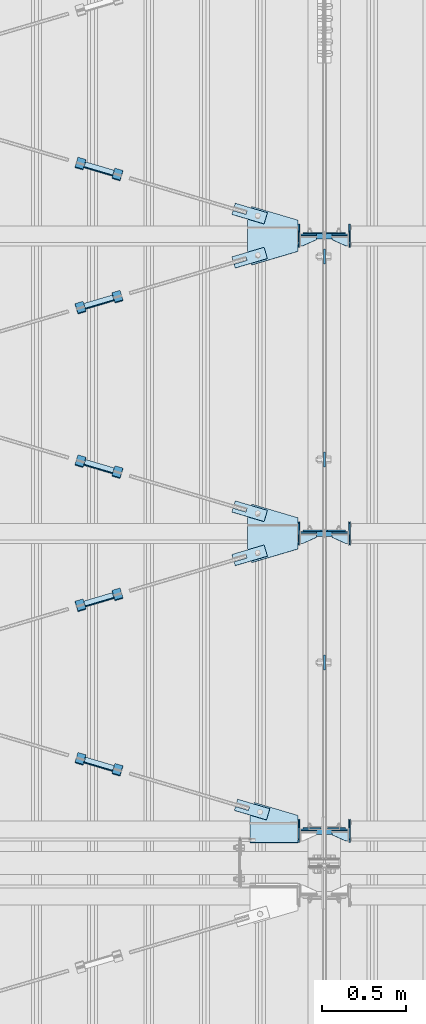
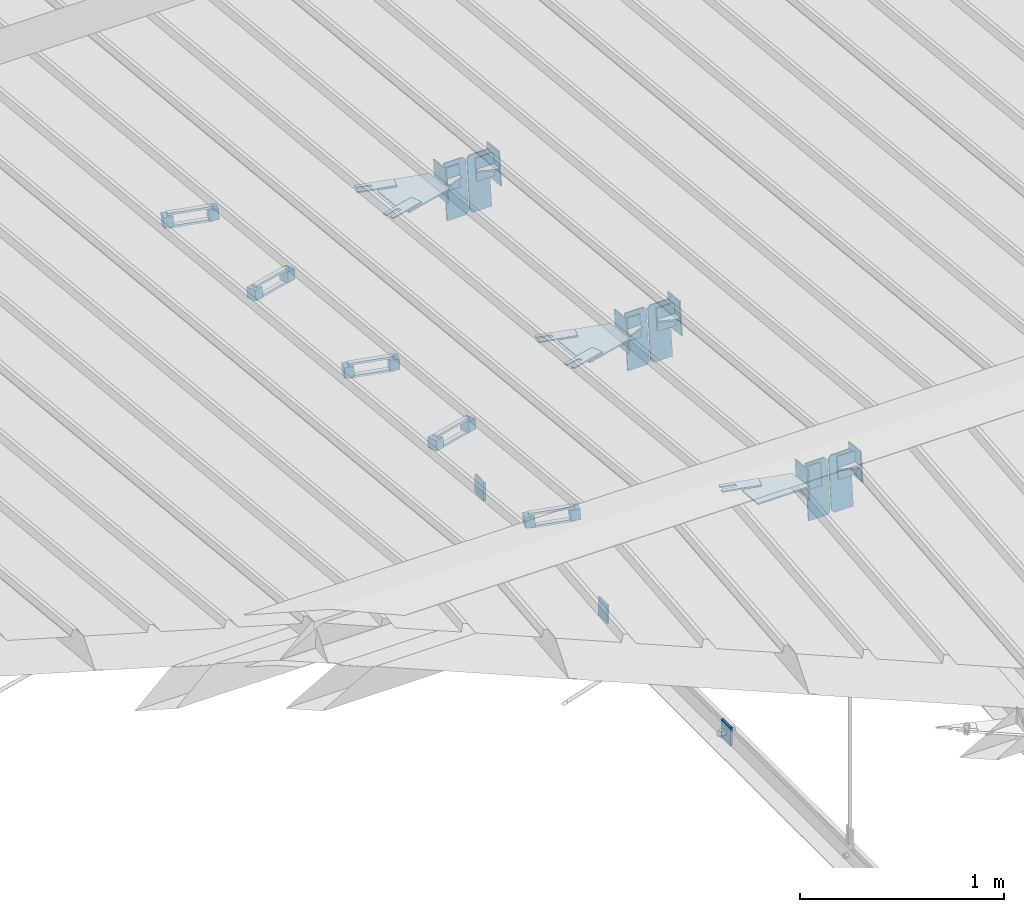
# One storey, part 120 of 709: 54 plates, 5 openings, 20 elements without a shape of their own.
"""IFC4 building model written with IfcOpenShell, lengths in millimetres."""

from ifc_helpers import new_model, si_unit, direction, frame, origin_with_axes, place, context, subcontext, project, spatial, line, indexed_curve, outline, extrude, material, element, aggregate, save


model = new_model("IFC4")

# Units and contexts
model_context = context("Model", 3, precision=0.2, world=origin_with_axes(), true_north=direction((0.0, 1.0)))
body_context = subcontext(model_context, "Body", "Model", "MODEL_VIEW")
ifc_project = project(units=[si_unit("LENGTHUNIT", "METRE", prefix="MILLI"), si_unit("AREAUNIT", "SQUARE_METRE"), si_unit("VOLUMEUNIT", "CUBIC_METRE"), si_unit("MASSUNIT", "GRAM", prefix="KILO"), si_unit("TIMEUNIT", "SECOND"), si_unit("PLANEANGLEUNIT", "RADIAN"), si_unit("SOLIDANGLEUNIT", "STERADIAN"), si_unit("THERMODYNAMICTEMPERATUREUNIT", "DEGREE_CELSIUS"), si_unit("LUMINOUSINTENSITYUNIT", "LUMEN")], contexts=[model_context])

# Site, building, storey
site_placement = place(None, origin_with_axes())
site = spatial("IfcSite", under=ifc_project, at=site_placement, CompositionType="ELEMENT")
building_placement = place(site_placement, origin_with_axes())
building = spatial("IfcBuilding", under=site, at=building_placement, Name="Undefined", CompositionType="ELEMENT")
storey_placement = place(building_placement, origin_with_axes())
storey = spatial("IfcBuildingStorey", under=building, at=storey_placement, Name="Undefined", CompositionType="ELEMENT", Elevation=0.0)

# Assembly, plates
assembly_1_placement = place(storey_placement, frame((10000.0, 21654.0, 7089.70002), z_axis=(-1.0, 0.0, 0.0), x_axis=(0.0, -0.9950371902, 0.099503719)))
assembly_1 = element("IfcElementAssembly", 1, at=assembly_1_placement, inside=storey)
ifc_material_1 = material(Name="C355-6", Category="STEEL")
plate_1_placement = place(assembly_1_placement, frame((10515.43997, 163.0, 127.0), z_axis=(-1.0, 0.0, 0.0), x_axis=(0.0, 0.0, -1.0)))
plate_1 = element("IfcPlate", 2, at=plate_1_placement, material=ifc_material_1, ObjectType="589", context=body_context, shape_type="SolidModel", body=[
    extrude(outline(indexed_curve([(0.0, 0.0), (108.0, 0.0), (123.0, 15.0), (123.0, 311.0), (108.0, 326.0), (0.0, 326.0)], segments=[line(1, 2, 3, 4, 5, 6, 1)])), frame((0.0, 0.0, 4.0), z_axis=(0.0, 0.0, 1.0), x_axis=(1.0, 0.0, 0.0)), (0.0, 0.0, -1.0), 8.0),
])
plate_2_placement = place(assembly_1_placement, frame((6951.15059, 163.0, 127.0), z_axis=(-1.0, 0.0, 0.0), x_axis=(0.0, 0.0, -1.0)))
plate_2 = element("IfcPlate", 3, at=plate_2_placement, material=ifc_material_1, ObjectType="585", context=body_context, shape_type="SolidModel", body=[
    extrude(outline(indexed_curve([(0.0, 0.0), (108.0, 0.0), (123.0, 15.0), (123.0, 311.0), (108.0, 326.0), (0.0, 326.0)], segments=[line(1, 2, 3, 4, 5, 6, 1)])), frame((0.0, 0.0, 4.0), z_axis=(0.0, 0.0, 1.0), x_axis=(1.0, 0.0, 0.0)), (0.0, 0.0, -1.0), 8.0),
])
plate_3_placement = place(assembly_1_placement, frame((8733.29528, 163.0, -127.0), z_axis=(1.0, 0.0, 0.0), x_axis=(0.0, 0.0, 1.0)))
plate_3 = element("IfcPlate", 4, at=plate_3_placement, material=ifc_material_1, ObjectType="585", context=body_context, shape_type="SolidModel", body=[
    extrude(outline(indexed_curve([(0.0, 0.0), (108.0, 0.0), (123.0, 15.0), (123.0, 311.0), (108.0, 326.0), (0.0, 326.0)], segments=[line(1, 2, 3, 4, 5, 6, 1)])), frame((0.0, 0.0, 4.0), z_axis=(0.0, 0.0, 1.0), x_axis=(1.0, 0.0, 0.0)), (0.0, 0.0, -1.0), 8.0),
])
plate_4_placement = place(assembly_1_placement, frame((8733.29528, 163.0, 127.0), z_axis=(-1.0, 0.0, 0.0), x_axis=(0.0, 0.0, -1.0)))
plate_4 = element("IfcPlate", 5, at=plate_4_placement, material=ifc_material_1, ObjectType="585", context=body_context, shape_type="SolidModel", body=[
    extrude(outline(indexed_curve([(0.0, 0.0), (108.0, 0.0), (123.0, 15.0), (123.0, 311.0), (108.0, 326.0), (0.0, 326.0)], segments=[line(1, 2, 3, 4, 5, 6, 1)])), frame((0.0, 0.0, 4.0), z_axis=(0.0, 0.0, 1.0), x_axis=(1.0, 0.0, 0.0)), (0.0, 0.0, -1.0), 8.0),
])
plate_5_placement = place(assembly_1_placement, frame((10515.43997, 163.0, -127.0), z_axis=(1.0, 0.0, 0.0), x_axis=(0.0, 0.0, 1.0)))
plate_5 = element("IfcPlate", 6, at=plate_5_placement, material=ifc_material_1, ObjectType="589", context=body_context, shape_type="SolidModel", body=[
    extrude(outline(indexed_curve([(0.0, 0.0), (108.0, 0.0), (123.0, 15.0), (123.0, 311.0), (108.0, 326.0), (0.0, 326.0)], segments=[line(1, 2, 3, 4, 5, 6, 1)])), frame((0.0, 0.0, 4.0), z_axis=(0.0, 0.0, 1.0), x_axis=(1.0, 0.0, 0.0)), (0.0, 0.0, -1.0), 8.0),
])
plate_6_placement = place(assembly_1_placement, frame((6951.15059, 163.0, -127.0), z_axis=(1.0, 0.0, 0.0), x_axis=(0.0, 0.0, 1.0)))
plate_6 = element("IfcPlate", 7, at=plate_6_placement, material=ifc_material_1, ObjectType="585", context=body_context, shape_type="SolidModel", body=[
    extrude(outline(indexed_curve([(0.0, 0.0), (108.0, 0.0), (123.0, 15.0), (123.0, 311.0), (108.0, 326.0), (0.0, 326.0)], segments=[line(1, 2, 3, 4, 5, 6, 1)])), frame((0.0, 0.0, 4.0), z_axis=(0.0, 0.0, 1.0), x_axis=(1.0, 0.0, 0.0)), (0.0, 0.0, -1.0), 8.0),
])
aggregate(assembly_1, [plate_1, plate_2, plate_3, plate_4, plate_5, plate_6])

# Assembly, plate
assembly_2_placement = place(storey_placement, frame((10000.0, 12149.25, 6100.00002), z_axis=(-1.0, 0.0, 0.0), x_axis=(0.0, 1.0, 0.0)))
assembly_2 = element("IfcElementAssembly", 8, at=assembly_2_placement, inside=storey)
plate_7_placement = place(assembly_2_placement, origin_with_axes())
plate_7 = element("IfcPlate", 9, at=plate_7_placement, material=ifc_material_1, ObjectType="491", context=body_context, shape_type="SolidModel", body=[
    extrude(outline(indexed_curve([(0.0, 0.0), (90.0, 0.0), (90.0, 110.0), (0.0, 110.0)], segments=[line(1, 2, 3, 4, 1)])), frame((0.0, 0.0, 6.0), z_axis=(0.0, 0.0, 1.0), x_axis=(1.0, 0.0, 0.0)), (0.0, 0.0, -1.0), 12.0),
])
aggregate(assembly_2, [plate_7])

assembly_3_placement = place(storey_placement, frame((10000.0, 13358.5, 6100.00002), z_axis=(-1.0, 0.0, 0.0), x_axis=(0.0, 1.0, 0.0)))
assembly_3 = element("IfcElementAssembly", 10, at=assembly_3_placement, inside=storey)
plate_8_placement = place(assembly_3_placement, origin_with_axes())
plate_8 = element("IfcPlate", 11, at=plate_8_placement, material=ifc_material_1, ObjectType="491", context=body_context, shape_type="SolidModel", body=[
    extrude(outline(indexed_curve([(0.0, 0.0), (90.0, 0.0), (90.0, 110.0), (0.0, 110.0)], segments=[line(1, 2, 3, 4, 1)])), frame((0.0, 0.0, 6.0), z_axis=(0.0, 0.0, 1.0), x_axis=(1.0, 0.0, 0.0)), (0.0, 0.0, -1.0), 12.0),
])
aggregate(assembly_3, [plate_8])

assembly_4_placement = place(storey_placement, frame((10000.0, 14567.75, 6100.00002), z_axis=(-1.0, 0.0, 0.0), x_axis=(0.0, 1.0, 0.0)))
assembly_4 = element("IfcElementAssembly", 12, at=assembly_4_placement, inside=storey)
plate_9_placement = place(assembly_4_placement, origin_with_axes())
plate_9 = element("IfcPlate", 13, at=plate_9_placement, material=ifc_material_1, ObjectType="491", context=body_context, shape_type="SolidModel", body=[
    extrude(outline(indexed_curve([(0.0, 0.0), (90.0, 0.0), (90.0, 110.0), (0.0, 110.0)], segments=[line(1, 2, 3, 4, 1)])), frame((0.0, 0.0, 6.0), z_axis=(0.0, 0.0, 1.0), x_axis=(1.0, 0.0, 0.0)), (0.0, 0.0, -1.0), 12.0),
])
aggregate(assembly_4, [plate_9])

# Assembly, plate, voiding feature
assembly_5_placement = place(storey_placement, frame((8657.949, 12567.50268, 8079.75375), z_axis=(0.2847296511, -0.9538504697, 0.095385047), x_axis=(0.9586078582, 0.2833165921, -0.028331659)))
assembly_5 = element("IfcElementAssembly", 14, at=assembly_5_placement, inside=storey)
plate_10_placement = place(assembly_5_placement, frame((1036.31721, 0.0, 35.0), z_axis=(0.0, 1.0, 0.0), x_axis=(0.0, 0.0, -1.0)))
plate_10 = element("IfcPlate", 15, at=plate_10_placement, material=ifc_material_1, ObjectType="574", context=body_context, shape_type="SolidModel", body=[
    extrude(outline(indexed_curve([(0.0, 0.0), (70.0, 0.0), (70.0, 200.0), (0.0, 200.0)], segments=[line(1, 2, 3, 4, 1)])), frame((0.0, 0.0, 4.0), z_axis=(0.0, 0.0, 1.0), x_axis=(1.0, 0.0, 0.0)), (0.0, 0.0, -1.0), 8.0),
])
voiding_feature_1_placement = place(plate_10_placement, frame((24.0, 120.0, 0.0), z_axis=(0.0, 0.0, 1.0), x_axis=(1.0, 0.0, 0.0)))
element("IfcVoidingFeature", 16, at=voiding_feature_1_placement, cuts=plate_10, Name="PLATE", PredefinedType="HOLE", context=body_context, shape_type="SolidModel", body=[
    extrude(outline(indexed_curve([(0.0, 0.0), (22.0, 0.0), (22.0, 85.0), (0.0, 85.0)], segments=[line(1, 2, 3, 4, 1)])), frame((0.0, 0.0, 6.5), z_axis=(0.0, 0.0, 1.0), x_axis=(1.0, 0.0, 0.0)), (0.0, 0.0, -1.0), 13.0),
])
aggregate(assembly_5, [plate_10])

# Assembly, plates
assembly_6_placement = place(storey_placement, frame((8776.73079, 12574.45368, 8109.20827), z_axis=(-0.9586078582, -0.2833165918, 0.0283316592), x_axis=(-0.2847296509, 0.9538504698, -0.095385047)))
assembly_6 = element("IfcElementAssembly", 17, at=assembly_6_placement, inside=storey)
ifc_material_2 = material(Name="Steel_Undefined", Category="STEEL")
plate_11_placement = place(assembly_6_placement, frame((15.0, -6.0, 230.0), z_axis=(0.0, 1.0, 0.0), x_axis=(1.0, 0.0, 0.0)))
plate_11 = element("IfcPlate", 18, at=plate_11_placement, material=ifc_material_2, ObjectType="484", context=body_context, shape_type="SolidModel", body=[
    extrude(outline(indexed_curve([(0.0, 0.0), (30.0, 0.0), (30.0, 230.0), (0.0, 230.0)], segments=[line(1, 2, 3, 4, 1)])), frame((0.0, 0.0, 6.0), z_axis=(0.0, 0.0, 1.0), x_axis=(1.0, 0.0, 0.0)), (0.0, 0.0, -1.0), 12.0),
])
plate_12_placement = place(assembly_6_placement, frame((15.0, 66.0, 230.0), z_axis=(0.0, 1.0, 0.0), x_axis=(1.0, 0.0, 0.0)))
plate_12 = element("IfcPlate", 19, at=plate_12_placement, material=ifc_material_2, ObjectType="484", context=body_context, shape_type="SolidModel", body=[
    extrude(outline(indexed_curve([(0.0, 0.0), (30.0, 0.0), (30.0, 230.0), (0.0, 230.0)], segments=[line(1, 2, 3, 4, 1)])), frame((0.0, 0.0, 6.0), z_axis=(0.0, 0.0, 1.0), x_axis=(1.0, 0.0, 0.0)), (0.0, 0.0, -1.0), 12.0),
])
plate_13_placement = place(assembly_6_placement, frame((0.0, 0.0, 230.0), z_axis=(0.0, 0.0, 1.0), x_axis=(1.0, 0.0, 0.0)))
plate_13 = element("IfcPlate", 20, at=plate_13_placement, material=ifc_material_2, ObjectType="483", context=body_context, shape_type="SolidModel", body=[
    extrude(outline(indexed_curve([(0.0, 0.0), (60.0, 0.0), (60.0, 60.0), (0.0, 60.0)], segments=[line(1, 2, 3, 4, 1)])), frame((0.0, 0.0, 25.0), z_axis=(0.0, 0.0, 1.0), x_axis=(1.0, 0.0, 0.0)), (0.0, 0.0, -1.0), 50.0),
])
plate_14_placement = place(assembly_6_placement, origin_with_axes())
plate_14 = element("IfcPlate", 21, at=plate_14_placement, material=ifc_material_2, ObjectType="482", context=body_context, shape_type="SolidModel", body=[
    extrude(outline(indexed_curve([(0.0, 0.0), (60.0, 0.0), (60.0, 60.0), (0.0, 60.0)], segments=[line(1, 2, 3, 4, 1)])), frame((0.0, 0.0, 25.0), z_axis=(0.0, 0.0, 1.0), x_axis=(1.0, 0.0, 0.0)), (0.0, 0.0, -1.0), 50.0),
])
aggregate(assembly_6, [plate_11, plate_12, plate_13, plate_14])

# Assembly, plate, voiding feature
assembly_7_placement = place(storey_placement, frame((8657.949, 11587.48889, 8177.75513), z_axis=(-0.2847296511, -0.9538504697, 0.095385047), x_axis=(0.9586078582, -0.2833165921, 0.028331659)))
assembly_7 = element("IfcElementAssembly", 22, at=assembly_7_placement, inside=storey)
plate_15_placement = place(assembly_7_placement, frame((1051.31721, 0.0, 35.0), z_axis=(0.0, 1.0, 0.0), x_axis=(0.0, 0.0, -1.0)))
plate_15 = element("IfcPlate", 23, at=plate_15_placement, material=ifc_material_1, ObjectType="574", context=body_context, shape_type="SolidModel", body=[
    extrude(outline(indexed_curve([(0.0, 0.0), (70.0, 0.0), (70.0, 200.0), (0.0, 200.0)], segments=[line(1, 2, 3, 4, 1)])), frame((0.0, 0.0, 4.0), z_axis=(0.0, 0.0, 1.0), x_axis=(1.0, 0.0, 0.0)), (0.0, 0.0, -1.0), 8.0),
])
voiding_feature_2_placement = place(plate_15_placement, frame((24.0, 120.0, 0.0), z_axis=(0.0, 0.0, 1.0), x_axis=(1.0, 0.0, 0.0)))
element("IfcVoidingFeature", 24, at=voiding_feature_2_placement, cuts=plate_15, Name="PLATE", PredefinedType="HOLE", context=body_context, shape_type="SolidModel", body=[
    extrude(outline(indexed_curve([(0.0, 0.0), (22.0, 0.0), (22.0, 85.0), (0.0, 85.0)], segments=[line(1, 2, 3, 4, 1)])), frame((0.0, 0.0, 6.5), z_axis=(0.0, 0.0, 1.0), x_axis=(1.0, 0.0, 0.0)), (0.0, 0.0, -1.0), 13.0),
])
aggregate(assembly_7, [plate_15])

# Assembly, plates
assembly_8_placement = place(storey_placement, frame((8759.64701, 11529.27708, 8213.72594), z_axis=(-0.9586078582, 0.2833165918, -0.0283316592), x_axis=(0.2847296509, 0.9538504698, -0.095385047)))
assembly_8 = element("IfcElementAssembly", 25, at=assembly_8_placement, inside=storey)
plate_16_placement = place(assembly_8_placement, frame((15.0, 66.0, 230.0), z_axis=(0.0, 1.0, 0.0), x_axis=(1.0, 0.0, 0.0)))
plate_16 = element("IfcPlate", 26, at=plate_16_placement, material=ifc_material_2, ObjectType="484", context=body_context, shape_type="SolidModel", body=[
    extrude(outline(indexed_curve([(0.0, 0.0), (30.0, 0.0), (30.0, 230.0), (0.0, 230.0)], segments=[line(1, 2, 3, 4, 1)])), frame((0.0, 0.0, 6.0), z_axis=(0.0, 0.0, 1.0), x_axis=(1.0, 0.0, 0.0)), (0.0, 0.0, -1.0), 12.0),
])
plate_17_placement = place(assembly_8_placement, frame((0.0, 0.0, 230.0), z_axis=(0.0, 0.0, 1.0), x_axis=(1.0, 0.0, 0.0)))
plate_17 = element("IfcPlate", 27, at=plate_17_placement, material=ifc_material_2, ObjectType="483", context=body_context, shape_type="SolidModel", body=[
    extrude(outline(indexed_curve([(0.0, 0.0), (60.0, 0.0), (60.0, 60.0), (0.0, 60.0)], segments=[line(1, 2, 3, 4, 1)])), frame((0.0, 0.0, 25.0), z_axis=(0.0, 0.0, 1.0), x_axis=(1.0, 0.0, 0.0)), (0.0, 0.0, -1.0), 50.0),
])
plate_18_placement = place(assembly_8_placement, frame((15.0, -6.0, 230.0), z_axis=(0.0, 1.0, 0.0), x_axis=(1.0, 0.0, 0.0)))
plate_18 = element("IfcPlate", 28, at=plate_18_placement, material=ifc_material_2, ObjectType="484", context=body_context, shape_type="SolidModel", body=[
    extrude(outline(indexed_curve([(0.0, 0.0), (30.0, 0.0), (30.0, 230.0), (0.0, 230.0)], segments=[line(1, 2, 3, 4, 1)])), frame((0.0, 0.0, 6.0), z_axis=(0.0, 0.0, 1.0), x_axis=(1.0, 0.0, 0.0)), (0.0, 0.0, -1.0), 12.0),
])
plate_19_placement = place(assembly_8_placement, origin_with_axes())
plate_19 = element("IfcPlate", 29, at=plate_19_placement, material=ifc_material_2, ObjectType="482", context=body_context, shape_type="SolidModel", body=[
    extrude(outline(indexed_curve([(0.0, 0.0), (60.0, 0.0), (60.0, 60.0), (0.0, 60.0)], segments=[line(1, 2, 3, 4, 1)])), frame((0.0, 0.0, 25.0), z_axis=(0.0, 0.0, 1.0), x_axis=(1.0, 0.0, 0.0)), (0.0, 0.0, -1.0), 50.0),
])
aggregate(assembly_8, [plate_16, plate_17, plate_18, plate_19])

# Assembly, plate, voiding feature
assembly_9_placement = place(storey_placement, frame((8657.949, 14340.80292, 7902.42372), z_axis=(0.2847296511, -0.9538504697, 0.095385047), x_axis=(0.9586078582, 0.2833165921, -0.028331659)))
assembly_9 = element("IfcElementAssembly", 30, at=assembly_9_placement, inside=storey)
plate_20_placement = place(assembly_9_placement, frame((1036.31721, 0.0, 35.0), z_axis=(0.0, 1.0, 0.0), x_axis=(0.0, 0.0, -1.0)))
plate_20 = element("IfcPlate", 31, at=plate_20_placement, material=ifc_material_1, ObjectType="574", context=body_context, shape_type="SolidModel", body=[
    extrude(outline(indexed_curve([(0.0, 0.0), (70.0, 0.0), (70.0, 200.0), (0.0, 200.0)], segments=[line(1, 2, 3, 4, 1)])), frame((0.0, 0.0, 4.0), z_axis=(0.0, 0.0, 1.0), x_axis=(1.0, 0.0, 0.0)), (0.0, 0.0, -1.0), 8.0),
])
voiding_feature_3_placement = place(plate_20_placement, frame((24.0, 120.0, 0.0), z_axis=(0.0, 0.0, 1.0), x_axis=(1.0, 0.0, 0.0)))
element("IfcVoidingFeature", 32, at=voiding_feature_3_placement, cuts=plate_20, Name="PLATE", PredefinedType="HOLE", context=body_context, shape_type="SolidModel", body=[
    extrude(outline(indexed_curve([(0.0, 0.0), (22.0, 0.0), (22.0, 85.0), (0.0, 85.0)], segments=[line(1, 2, 3, 4, 1)])), frame((0.0, 0.0, 6.5), z_axis=(0.0, 0.0, 1.0), x_axis=(1.0, 0.0, 0.0)), (0.0, 0.0, -1.0), 13.0),
])
aggregate(assembly_9, [plate_20])

# Assembly, plates
assembly_10_placement = place(storey_placement, frame((8776.73079, 14347.75393, 7931.87825), z_axis=(-0.9586078582, -0.2833165918, 0.0283316592), x_axis=(-0.2847296509, 0.9538504698, -0.095385047)))
assembly_10 = element("IfcElementAssembly", 33, at=assembly_10_placement, inside=storey)
plate_21_placement = place(assembly_10_placement, frame((15.0, 66.0, 230.0), z_axis=(0.0, 1.0, 0.0), x_axis=(1.0, 0.0, 0.0)))
plate_21 = element("IfcPlate", 34, at=plate_21_placement, material=ifc_material_2, ObjectType="484", context=body_context, shape_type="SolidModel", body=[
    extrude(outline(indexed_curve([(0.0, 0.0), (30.0, 0.0), (30.0, 230.0), (0.0, 230.0)], segments=[line(1, 2, 3, 4, 1)])), frame((0.0, 0.0, 6.0), z_axis=(0.0, 0.0, 1.0), x_axis=(1.0, 0.0, 0.0)), (0.0, 0.0, -1.0), 12.0),
])
plate_22_placement = place(assembly_10_placement, frame((15.0, -6.0, 230.0), z_axis=(0.0, 1.0, 0.0), x_axis=(1.0, 0.0, 0.0)))
plate_22 = element("IfcPlate", 35, at=plate_22_placement, material=ifc_material_2, ObjectType="484", context=body_context, shape_type="SolidModel", body=[
    extrude(outline(indexed_curve([(0.0, 0.0), (30.0, 0.0), (30.0, 230.0), (0.0, 230.0)], segments=[line(1, 2, 3, 4, 1)])), frame((0.0, 0.0, 6.0), z_axis=(0.0, 0.0, 1.0), x_axis=(1.0, 0.0, 0.0)), (0.0, 0.0, -1.0), 12.0),
])
plate_23_placement = place(assembly_10_placement, origin_with_axes())
plate_23 = element("IfcPlate", 36, at=plate_23_placement, material=ifc_material_2, ObjectType="482", context=body_context, shape_type="SolidModel", body=[
    extrude(outline(indexed_curve([(0.0, 0.0), (60.0, 0.0), (60.0, 60.0), (0.0, 60.0)], segments=[line(1, 2, 3, 4, 1)])), frame((0.0, 0.0, 25.0), z_axis=(0.0, 0.0, 1.0), x_axis=(1.0, 0.0, 0.0)), (0.0, 0.0, -1.0), 50.0),
])
plate_24_placement = place(assembly_10_placement, frame((0.0, 0.0, 230.0), z_axis=(0.0, 0.0, 1.0), x_axis=(1.0, 0.0, 0.0)))
plate_24 = element("IfcPlate", 37, at=plate_24_placement, material=ifc_material_2, ObjectType="483", context=body_context, shape_type="SolidModel", body=[
    extrude(outline(indexed_curve([(0.0, 0.0), (60.0, 0.0), (60.0, 60.0), (0.0, 60.0)], segments=[line(1, 2, 3, 4, 1)])), frame((0.0, 0.0, 25.0), z_axis=(0.0, 0.0, 1.0), x_axis=(1.0, 0.0, 0.0)), (0.0, 0.0, -1.0), 50.0),
])
aggregate(assembly_10, [plate_21, plate_22, plate_23, plate_24])

# Assembly, plate, voiding feature
assembly_11_placement = place(storey_placement, frame((8657.949, 13360.78913, 8000.4251), z_axis=(-0.2847296511, -0.9538504697, 0.095385047), x_axis=(0.9586078582, -0.2833165921, 0.028331659)))
assembly_11 = element("IfcElementAssembly", 38, at=assembly_11_placement, inside=storey)
plate_25_placement = place(assembly_11_placement, frame((1036.31721, 0.0, 35.0), z_axis=(0.0, 1.0, 0.0), x_axis=(0.0, 0.0, -1.0)))
plate_25 = element("IfcPlate", 39, at=plate_25_placement, material=ifc_material_1, ObjectType="574", context=body_context, shape_type="SolidModel", body=[
    extrude(outline(indexed_curve([(0.0, 0.0), (70.0, 0.0), (70.0, 200.0), (0.0, 200.0)], segments=[line(1, 2, 3, 4, 1)])), frame((0.0, 0.0, 4.0), z_axis=(0.0, 0.0, 1.0), x_axis=(1.0, 0.0, 0.0)), (0.0, 0.0, -1.0), 8.0),
])
voiding_feature_4_placement = place(plate_25_placement, frame((24.0, 120.0, 0.0), z_axis=(0.0, 0.0, 1.0), x_axis=(1.0, 0.0, 0.0)))
element("IfcVoidingFeature", 40, at=voiding_feature_4_placement, cuts=plate_25, Name="PLATE", PredefinedType="HOLE", context=body_context, shape_type="SolidModel", body=[
    extrude(outline(indexed_curve([(0.0, 0.0), (22.0, 0.0), (22.0, 85.0), (0.0, 85.0)], segments=[line(1, 2, 3, 4, 1)])), frame((0.0, 0.0, 6.5), z_axis=(0.0, 0.0, 1.0), x_axis=(1.0, 0.0, 0.0)), (0.0, 0.0, -1.0), 13.0),
])
aggregate(assembly_11, [plate_25])

# Assembly, plates
assembly_12_placement = place(storey_placement, frame((8759.64701, 13302.57732, 8036.39591), z_axis=(-0.9586078582, 0.2833165918, -0.0283316592), x_axis=(0.2847296509, 0.9538504698, -0.095385047)))
assembly_12 = element("IfcElementAssembly", 41, at=assembly_12_placement, inside=storey)
plate_26_placement = place(assembly_12_placement, origin_with_axes())
plate_26 = element("IfcPlate", 42, at=plate_26_placement, material=ifc_material_2, ObjectType="482", context=body_context, shape_type="SolidModel", body=[
    extrude(outline(indexed_curve([(0.0, 0.0), (60.0, 0.0), (60.0, 60.0), (0.0, 60.0)], segments=[line(1, 2, 3, 4, 1)])), frame((0.0, 0.0, 25.0), z_axis=(0.0, 0.0, 1.0), x_axis=(1.0, 0.0, 0.0)), (0.0, 0.0, -1.0), 50.0),
])
plate_27_placement = place(assembly_12_placement, frame((15.0, -6.0, 230.0), z_axis=(0.0, 1.0, 0.0), x_axis=(1.0, 0.0, 0.0)))
plate_27 = element("IfcPlate", 43, at=plate_27_placement, material=ifc_material_2, ObjectType="484", context=body_context, shape_type="SolidModel", body=[
    extrude(outline(indexed_curve([(0.0, 0.0), (30.0, 0.0), (30.0, 230.0), (0.0, 230.0)], segments=[line(1, 2, 3, 4, 1)])), frame((0.0, 0.0, 6.0), z_axis=(0.0, 0.0, 1.0), x_axis=(1.0, 0.0, 0.0)), (0.0, 0.0, -1.0), 12.0),
])
plate_28_placement = place(assembly_12_placement, frame((15.0, 66.0, 230.0), z_axis=(0.0, 1.0, 0.0), x_axis=(1.0, 0.0, 0.0)))
plate_28 = element("IfcPlate", 44, at=plate_28_placement, material=ifc_material_2, ObjectType="484", context=body_context, shape_type="SolidModel", body=[
    extrude(outline(indexed_curve([(0.0, 0.0), (30.0, 0.0), (30.0, 230.0), (0.0, 230.0)], segments=[line(1, 2, 3, 4, 1)])), frame((0.0, 0.0, 6.0), z_axis=(0.0, 0.0, 1.0), x_axis=(1.0, 0.0, 0.0)), (0.0, 0.0, -1.0), 12.0),
])
plate_29_placement = place(assembly_12_placement, frame((0.0, 0.0, 230.0), z_axis=(0.0, 0.0, 1.0), x_axis=(1.0, 0.0, 0.0)))
plate_29 = element("IfcPlate", 45, at=plate_29_placement, material=ifc_material_2, ObjectType="483", context=body_context, shape_type="SolidModel", body=[
    extrude(outline(indexed_curve([(0.0, 0.0), (60.0, 0.0), (60.0, 60.0), (0.0, 60.0)], segments=[line(1, 2, 3, 4, 1)])), frame((0.0, 0.0, 25.0), z_axis=(0.0, 0.0, 1.0), x_axis=(1.0, 0.0, 0.0)), (0.0, 0.0, -1.0), 50.0),
])
aggregate(assembly_12, [plate_26, plate_27, plate_28, plate_29])

# Assembly, plate, voiding feature
assembly_13_placement = place(storey_placement, frame((8657.949, 15134.08938, 7823.09508), z_axis=(-0.2847296511, -0.9538504697, 0.095385047), x_axis=(0.9586078582, -0.2833165921, 0.028331659)))
assembly_13 = element("IfcElementAssembly", 46, at=assembly_13_placement, inside=storey)
plate_30_placement = place(assembly_13_placement, frame((1036.31721, 0.0, 35.0), z_axis=(0.0, 1.0, 0.0), x_axis=(0.0, 0.0, -1.0)))
plate_30 = element("IfcPlate", 47, at=plate_30_placement, material=ifc_material_1, ObjectType="574", context=body_context, shape_type="SolidModel", body=[
    extrude(outline(indexed_curve([(0.0, 0.0), (70.0, 0.0), (70.0, 200.0), (0.0, 200.0)], segments=[line(1, 2, 3, 4, 1)])), frame((0.0, 0.0, 4.0), z_axis=(0.0, 0.0, 1.0), x_axis=(1.0, 0.0, 0.0)), (0.0, 0.0, -1.0), 8.0),
])
voiding_feature_5_placement = place(plate_30_placement, frame((24.0, 120.0, 0.0), z_axis=(0.0, 0.0, 1.0), x_axis=(1.0, 0.0, 0.0)))
element("IfcVoidingFeature", 48, at=voiding_feature_5_placement, cuts=plate_30, Name="PLATE", PredefinedType="HOLE", context=body_context, shape_type="SolidModel", body=[
    extrude(outline(indexed_curve([(0.0, 0.0), (22.0, 0.0), (22.0, 85.0), (0.0, 85.0)], segments=[line(1, 2, 3, 4, 1)])), frame((0.0, 0.0, 6.5), z_axis=(0.0, 0.0, 1.0), x_axis=(1.0, 0.0, 0.0)), (0.0, 0.0, -1.0), 13.0),
])
aggregate(assembly_13, [plate_30])

# Assembly, plates
assembly_14_placement = place(storey_placement, frame((8759.64701, 15075.87757, 7859.06589), z_axis=(-0.9586078582, 0.2833165918, -0.0283316592), x_axis=(0.2847296509, 0.9538504698, -0.095385047)))
assembly_14 = element("IfcElementAssembly", 49, at=assembly_14_placement, inside=storey)
plate_31_placement = place(assembly_14_placement, frame((15.0, 66.0, 230.0), z_axis=(0.0, 1.0, 0.0), x_axis=(1.0, 0.0, 0.0)))
plate_31 = element("IfcPlate", 50, at=plate_31_placement, material=ifc_material_2, ObjectType="484", context=body_context, shape_type="SolidModel", body=[
    extrude(outline(indexed_curve([(0.0, 0.0), (30.0, 0.0), (30.0, 230.0), (0.0, 230.0)], segments=[line(1, 2, 3, 4, 1)])), frame((0.0, 0.0, 6.0), z_axis=(0.0, 0.0, 1.0), x_axis=(1.0, 0.0, 0.0)), (0.0, 0.0, -1.0), 12.0),
])
plate_32_placement = place(assembly_14_placement, origin_with_axes())
plate_32 = element("IfcPlate", 51, at=plate_32_placement, material=ifc_material_2, ObjectType="482", context=body_context, shape_type="SolidModel", body=[
    extrude(outline(indexed_curve([(0.0, 0.0), (60.0, 0.0), (60.0, 60.0), (0.0, 60.0)], segments=[line(1, 2, 3, 4, 1)])), frame((0.0, 0.0, 25.0), z_axis=(0.0, 0.0, 1.0), x_axis=(1.0, 0.0, 0.0)), (0.0, 0.0, -1.0), 50.0),
])
plate_33_placement = place(assembly_14_placement, frame((15.0, -6.0, 230.0), z_axis=(0.0, 1.0, 0.0), x_axis=(1.0, 0.0, 0.0)))
plate_33 = element("IfcPlate", 52, at=plate_33_placement, material=ifc_material_2, ObjectType="484", context=body_context, shape_type="SolidModel", body=[
    extrude(outline(indexed_curve([(0.0, 0.0), (30.0, 0.0), (30.0, 230.0), (0.0, 230.0)], segments=[line(1, 2, 3, 4, 1)])), frame((0.0, 0.0, 6.0), z_axis=(0.0, 0.0, 1.0), x_axis=(1.0, 0.0, 0.0)), (0.0, 0.0, -1.0), 12.0),
])
plate_34_placement = place(assembly_14_placement, frame((0.0, 0.0, 230.0), z_axis=(0.0, 0.0, 1.0), x_axis=(1.0, 0.0, 0.0)))
plate_34 = element("IfcPlate", 53, at=plate_34_placement, material=ifc_material_2, ObjectType="483", context=body_context, shape_type="SolidModel", body=[
    extrude(outline(indexed_curve([(0.0, 0.0), (60.0, 0.0), (60.0, 60.0), (0.0, 60.0)], segments=[line(1, 2, 3, 4, 1)])), frame((0.0, 0.0, 25.0), z_axis=(0.0, 0.0, 1.0), x_axis=(1.0, 0.0, 0.0)), (0.0, 0.0, -1.0), 50.0),
])
aggregate(assembly_14, [plate_31, plate_32, plate_33, plate_34])

assembly_15_placement = place(storey_placement, frame((10000.0, 11191.04467, 8219.40952), z_axis=(0.0, -0.9950371902, 0.099503719), x_axis=(-1.0, 0.0, 0.0)))
assembly_15 = element("IfcElementAssembly", 54, at=assembly_15_placement, inside=storey)
plate_35_placement = place(assembly_15_placement, frame((47.0, -65.0, 0.0), z_axis=(0.0, 0.0, 1.0), x_axis=(1.0, 0.0, 0.0)))
plate_35 = element("IfcPlate", 55, at=plate_35_placement, material=ifc_material_1, ObjectType="587", context=body_context, shape_type="SolidModel", body=[
    extrude(outline(indexed_curve([(0.0, 0.0), (100.0, 0.0), (100.0, 130.0), (0.0, 130.0)], segments=[line(1, 2, 3, 4, 1)])), frame((0.0, 0.0, 4.0), z_axis=(0.0, 0.0, 1.0), x_axis=(1.0, 0.0, 0.0)), (0.0, 0.0, -1.0), 8.0),
])
plate_36_placement = place(assembly_15_placement, frame((151.0, -88.0, -60.0), z_axis=(-1.0, 0.0, 0.0), x_axis=(0.0, 0.0, 1.0)))
plate_36 = element("IfcPlate", 56, at=plate_36_placement, material=ifc_material_1, ObjectType="590", context=body_context, shape_type="SolidModel", body=[
    extrude(outline(indexed_curve([(0.0, 0.0), (120.0, 0.0), (120.0, 176.0), (0.0, 176.0)], segments=[line(1, 2, 3, 4, 1)])), frame((0.0, 0.0, 4.0), z_axis=(0.0, 0.0, 1.0), x_axis=(1.0, 0.0, 0.0)), (0.0, 0.0, -1.0), 8.0),
])
plate_37_placement = place(assembly_15_placement, frame((442.92369, 10.0, 70.0), z_axis=(0.0, -1.0, 0.0), x_axis=(-1.0, 0.0, 0.0)))
plate_37 = element("IfcPlate", 57, at=plate_37_placement, material=ifc_material_1, Name="PLATE", ObjectType="577", context=body_context, shape_type="SolidModel", body=[
    extrude(outline(indexed_curve([(0.0, 0.0), (287.92369, 0.0), (287.92369, 162.98181), (25.62567, 240.89065), (0.0, 154.61594)], segments=[line(1, 2, 3, 4, 5, 1)])), frame((0.0, 0.0, 4.0), z_axis=(0.0, 0.0, 1.0), x_axis=(1.0, 0.0, 0.0)), (0.0, 0.0, -1.0), 8.0),
])
aggregate(assembly_15, [plate_35, plate_36, plate_37])

assembly_16_placement = place(storey_placement, frame((10000.0, 12963.34988, 8032.12913), z_axis=(0.0, -0.9950371902, 0.099503719), x_axis=(-1.0, 0.0, 0.0)))
assembly_16 = element("IfcElementAssembly", 58, at=assembly_16_placement, inside=storey)
plate_38_placement = place(assembly_16_placement, frame((47.0, 0.0, 60.0), z_axis=(0.0, 1.0, 0.0), x_axis=(1.0, 0.0, 0.0)))
plate_38 = element("IfcPlate", 59, at=plate_38_placement, material=ifc_material_1, ObjectType="588", context=body_context, shape_type="SolidModel", body=[
    extrude(outline(indexed_curve([(0.0, 36.0), (80.0, 0.0), (100.0, 0.0), (100.0, 56.0), (0.0, 56.0)], segments=[line(1, 2, 3, 4, 5, 1)])), frame((0.0, 0.0, 4.0), z_axis=(0.0, 0.0, 1.0), x_axis=(1.0, 0.0, 0.0)), (0.0, 0.0, -1.0), 8.0),
])
plate_39_placement = place(assembly_16_placement, frame((47.0, -65.0, 0.0), z_axis=(0.0, 0.0, 1.0), x_axis=(1.0, 0.0, 0.0)))
plate_39 = element("IfcPlate", 60, at=plate_39_placement, material=ifc_material_1, ObjectType="587", context=body_context, shape_type="SolidModel", body=[
    extrude(outline(indexed_curve([(0.0, 0.0), (100.0, 0.0), (100.0, 130.0), (0.0, 130.0)], segments=[line(1, 2, 3, 4, 1)])), frame((0.0, 0.0, 4.0), z_axis=(0.0, 0.0, 1.0), x_axis=(1.0, 0.0, 0.0)), (0.0, 0.0, -1.0), 8.0),
])
plate_40_placement = place(assembly_16_placement, frame((151.0, -98.0, -60.0), z_axis=(-1.0, 0.0, 0.0), x_axis=(0.0, 0.0, 1.0)))
plate_40 = element("IfcPlate", 61, at=plate_40_placement, material=ifc_material_1, ObjectType="586", context=body_context, shape_type="SolidModel", body=[
    extrude(outline(indexed_curve([(0.0, 0.0), (120.0, 0.0), (120.0, 196.0), (0.0, 196.0)], segments=[line(1, 2, 3, 4, 1)])), frame((0.0, 0.0, 4.0), z_axis=(0.0, 0.0, 1.0), x_axis=(1.0, 0.0, 0.0)), (0.0, 0.0, -1.0), 8.0),
])
plate_41_placement = place(assembly_16_placement, frame((154.99945, 0.0, 92.98165), z_axis=(0.0, -1.0, 0.0), x_axis=(0.0, 0.0, -1.0)))
plate_41 = element("IfcPlate", 62, at=plate_41_placement, material=ifc_material_1, ObjectType="576", context=body_context, shape_type="SolidModel", body=[
    extrude(outline(indexed_curve([(0.0, 0.0), (185.9633, 0.0), (268.14324, 276.67769), (181.86854, 302.30336), (4.09476, 302.30336), (-82.17995, 276.67769)], segments=[line(1, 2, 3, 4, 5, 6, 1)])), frame((0.0, 0.0, 4.0), z_axis=(0.0, 0.0, 1.0), x_axis=(1.0, 0.0, 0.0)), (0.0, 0.0, -1.0), 8.0),
])
aggregate(assembly_16, [plate_38, plate_39, plate_40, plate_41])

assembly_17_placement = place(storey_placement, frame((10000.0, 14736.65012, 7854.7991), z_axis=(0.0, -0.9950371902, 0.099503719), x_axis=(-1.0, 0.0, 0.0)))
assembly_17 = element("IfcElementAssembly", 63, at=assembly_17_placement, inside=storey)
plate_42_placement = place(assembly_17_placement, frame((151.0, -98.0, -60.0), z_axis=(-1.0, 0.0, 0.0), x_axis=(0.0, 0.0, 1.0)))
plate_42 = element("IfcPlate", 64, at=plate_42_placement, material=ifc_material_1, ObjectType="586", context=body_context, shape_type="SolidModel", body=[
    extrude(outline(indexed_curve([(0.0, 0.0), (120.0, 0.0), (120.0, 196.0), (0.0, 196.0)], segments=[line(1, 2, 3, 4, 1)])), frame((0.0, 0.0, 4.0), z_axis=(0.0, 0.0, 1.0), x_axis=(1.0, 0.0, 0.0)), (0.0, 0.0, -1.0), 8.0),
])
plate_43_placement = place(assembly_17_placement, frame((47.0, -65.0, 0.0), z_axis=(0.0, 0.0, 1.0), x_axis=(1.0, 0.0, 0.0)))
plate_43 = element("IfcPlate", 65, at=plate_43_placement, material=ifc_material_1, ObjectType="587", context=body_context, shape_type="SolidModel", body=[
    extrude(outline(indexed_curve([(0.0, 0.0), (100.0, 0.0), (100.0, 130.0), (0.0, 130.0)], segments=[line(1, 2, 3, 4, 1)])), frame((0.0, 0.0, 4.0), z_axis=(0.0, 0.0, 1.0), x_axis=(1.0, 0.0, 0.0)), (0.0, 0.0, -1.0), 8.0),
])
plate_44_placement = place(assembly_17_placement, frame((47.0, 0.0, 60.0), z_axis=(0.0, 1.0, 0.0), x_axis=(1.0, 0.0, 0.0)))
plate_44 = element("IfcPlate", 66, at=plate_44_placement, material=ifc_material_1, ObjectType="588", context=body_context, shape_type="SolidModel", body=[
    extrude(outline(indexed_curve([(0.0, 36.0), (80.0, 0.0), (100.0, 0.0), (100.0, 56.0), (0.0, 56.0)], segments=[line(1, 2, 3, 4, 5, 1)])), frame((0.0, 0.0, 4.0), z_axis=(0.0, 0.0, 1.0), x_axis=(1.0, 0.0, 0.0)), (0.0, 0.0, -1.0), 8.0),
])
plate_45_placement = place(assembly_17_placement, frame((154.99945, 0.0, 92.98165), z_axis=(0.0, -1.0, 0.0), x_axis=(0.0, 0.0, -1.0)))
plate_45 = element("IfcPlate", 67, at=plate_45_placement, material=ifc_material_1, ObjectType="576", context=body_context, shape_type="SolidModel", body=[
    extrude(outline(indexed_curve([(0.0, 0.0), (185.9633, 0.0), (268.14324, 276.67769), (181.86854, 302.30336), (4.09476, 302.30336), (-82.17995, 276.67769)], segments=[line(1, 2, 3, 4, 5, 6, 1)])), frame((0.0, 0.0, 4.0), z_axis=(0.0, 0.0, 1.0), x_axis=(1.0, 0.0, 0.0)), (0.0, 0.0, -1.0), 8.0),
])
aggregate(assembly_17, [plate_42, plate_43, plate_44, plate_45])

assembly_18_placement = place(storey_placement, frame((16000.0, 11191.04467, 8219.40952), z_axis=(0.0, -0.9950371902, 0.099503719), x_axis=(-1.0, 0.0, 0.0)))
assembly_18 = element("IfcElementAssembly", 68, at=assembly_18_placement, inside=storey)
plate_46_placement = place(assembly_18_placement, frame((5953.0, 0.0, 60.0), z_axis=(0.0, -1.0, 0.0), x_axis=(-1.0, 0.0, 0.0)))
plate_46 = element("IfcPlate", 69, at=plate_46_placement, material=ifc_material_1, ObjectType="588", context=body_context, shape_type="SolidModel", body=[
    extrude(outline(indexed_curve([(0.0, 36.0), (80.0, 0.0), (100.0, 0.0), (100.0, 56.0), (0.0, 56.0)], segments=[line(1, 2, 3, 4, 5, 1)])), frame((0.0, 0.0, 4.0), z_axis=(0.0, 0.0, 1.0), x_axis=(1.0, 0.0, 0.0)), (0.0, 0.0, -1.0), 8.0),
])
plate_47_placement = place(assembly_18_placement, frame((5849.0, -88.0, 60.0), z_axis=(1.0, 0.0, 0.0), x_axis=(0.0, 0.0, -1.0)))
plate_47 = element("IfcPlate", 70, at=plate_47_placement, material=ifc_material_1, ObjectType="590", context=body_context, shape_type="SolidModel", body=[
    extrude(outline(indexed_curve([(0.0, 0.0), (120.0, 0.0), (120.0, 176.0), (0.0, 176.0)], segments=[line(1, 2, 3, 4, 1)])), frame((0.0, 0.0, 4.0), z_axis=(0.0, 0.0, 1.0), x_axis=(1.0, 0.0, 0.0)), (0.0, 0.0, -1.0), 8.0),
])
plate_48_placement = place(assembly_18_placement, frame((5953.0, 65.0, 0.0), z_axis=(0.0, 0.0, 1.0), x_axis=(-1.0, 0.0, 0.0)))
plate_48 = element("IfcPlate", 71, at=plate_48_placement, material=ifc_material_1, ObjectType="587", context=body_context, shape_type="SolidModel", body=[
    extrude(outline(indexed_curve([(0.0, 0.0), (100.0, 0.0), (100.0, 130.0), (0.0, 130.0)], segments=[line(1, 2, 3, 4, 1)])), frame((0.0, 0.0, 4.0), z_axis=(0.0, 0.0, 1.0), x_axis=(1.0, 0.0, 0.0)), (0.0, 0.0, -1.0), 8.0),
])
aggregate(assembly_18, [plate_46, plate_47, plate_48])

assembly_19_placement = place(storey_placement, frame((16000.0, 12963.34988, 8032.12913), z_axis=(0.0, -0.9950371902, 0.099503719), x_axis=(-1.0, 0.0, 0.0)))
assembly_19 = element("IfcElementAssembly", 72, at=assembly_19_placement, inside=storey)
plate_49_placement = place(assembly_19_placement, frame((5953.0, 65.0, 0.0), z_axis=(0.0, 0.0, 1.0), x_axis=(-1.0, 0.0, 0.0)))
plate_49 = element("IfcPlate", 73, at=plate_49_placement, material=ifc_material_1, ObjectType="587", context=body_context, shape_type="SolidModel", body=[
    extrude(outline(indexed_curve([(0.0, 0.0), (100.0, 0.0), (100.0, 130.0), (0.0, 130.0)], segments=[line(1, 2, 3, 4, 1)])), frame((0.0, 0.0, 4.0), z_axis=(0.0, 0.0, 1.0), x_axis=(1.0, 0.0, 0.0)), (0.0, 0.0, -1.0), 8.0),
])
plate_50_placement = place(assembly_19_placement, frame((5849.0, -98.0, 60.0), z_axis=(1.0, 0.0, 0.0), x_axis=(0.0, 0.0, -1.0)))
plate_50 = element("IfcPlate", 74, at=plate_50_placement, material=ifc_material_1, ObjectType="586", context=body_context, shape_type="SolidModel", body=[
    extrude(outline(indexed_curve([(0.0, 0.0), (120.0, 0.0), (120.0, 196.0), (0.0, 196.0)], segments=[line(1, 2, 3, 4, 1)])), frame((0.0, 0.0, 4.0), z_axis=(0.0, 0.0, 1.0), x_axis=(1.0, 0.0, 0.0)), (0.0, 0.0, -1.0), 8.0),
])
plate_51_placement = place(assembly_19_placement, frame((5953.0, 0.0, 60.0), z_axis=(0.0, -1.0, 0.0), x_axis=(-1.0, 0.0, 0.0)))
plate_51 = element("IfcPlate", 75, at=plate_51_placement, material=ifc_material_1, ObjectType="588", context=body_context, shape_type="SolidModel", body=[
    extrude(outline(indexed_curve([(0.0, 36.0), (80.0, 0.0), (100.0, 0.0), (100.0, 56.0), (0.0, 56.0)], segments=[line(1, 2, 3, 4, 5, 1)])), frame((0.0, 0.0, 4.0), z_axis=(0.0, 0.0, 1.0), x_axis=(1.0, 0.0, 0.0)), (0.0, 0.0, -1.0), 8.0),
])
aggregate(assembly_19, [plate_49, plate_50, plate_51])

assembly_20_placement = place(storey_placement, frame((16000.0, 14736.65012, 7854.7991), z_axis=(0.0, -0.9950371902, 0.099503719), x_axis=(-1.0, 0.0, 0.0)))
assembly_20 = element("IfcElementAssembly", 76, at=assembly_20_placement, inside=storey)
plate_52_placement = place(assembly_20_placement, frame((5953.0, 0.0, 60.0), z_axis=(0.0, -1.0, 0.0), x_axis=(-1.0, 0.0, 0.0)))
plate_52 = element("IfcPlate", 77, at=plate_52_placement, material=ifc_material_1, ObjectType="588", context=body_context, shape_type="SolidModel", body=[
    extrude(outline(indexed_curve([(0.0, 36.0), (80.0, 0.0), (100.0, 0.0), (100.0, 56.0), (0.0, 56.0)], segments=[line(1, 2, 3, 4, 5, 1)])), frame((0.0, 0.0, 4.0), z_axis=(0.0, 0.0, 1.0), x_axis=(1.0, 0.0, 0.0)), (0.0, 0.0, -1.0), 8.0),
])
plate_53_placement = place(assembly_20_placement, frame((5953.0, 65.0, 0.0), z_axis=(0.0, 0.0, 1.0), x_axis=(-1.0, 0.0, 0.0)))
plate_53 = element("IfcPlate", 78, at=plate_53_placement, material=ifc_material_1, ObjectType="587", context=body_context, shape_type="SolidModel", body=[
    extrude(outline(indexed_curve([(0.0, 0.0), (100.0, 0.0), (100.0, 130.0), (0.0, 130.0)], segments=[line(1, 2, 3, 4, 1)])), frame((0.0, 0.0, 4.0), z_axis=(0.0, 0.0, 1.0), x_axis=(1.0, 0.0, 0.0)), (0.0, 0.0, -1.0), 8.0),
])
plate_54_placement = place(assembly_20_placement, frame((5849.0, -98.0, 60.0), z_axis=(1.0, 0.0, 0.0), x_axis=(0.0, 0.0, -1.0)))
plate_54 = element("IfcPlate", 79, at=plate_54_placement, material=ifc_material_1, ObjectType="586", context=body_context, shape_type="SolidModel", body=[
    extrude(outline(indexed_curve([(0.0, 0.0), (120.0, 0.0), (120.0, 196.0), (0.0, 196.0)], segments=[line(1, 2, 3, 4, 1)])), frame((0.0, 0.0, 4.0), z_axis=(0.0, 0.0, 1.0), x_axis=(1.0, 0.0, 0.0)), (0.0, 0.0, -1.0), 8.0),
])
aggregate(assembly_20, [plate_52, plate_53, plate_54])

save(model, "model.ifc")
